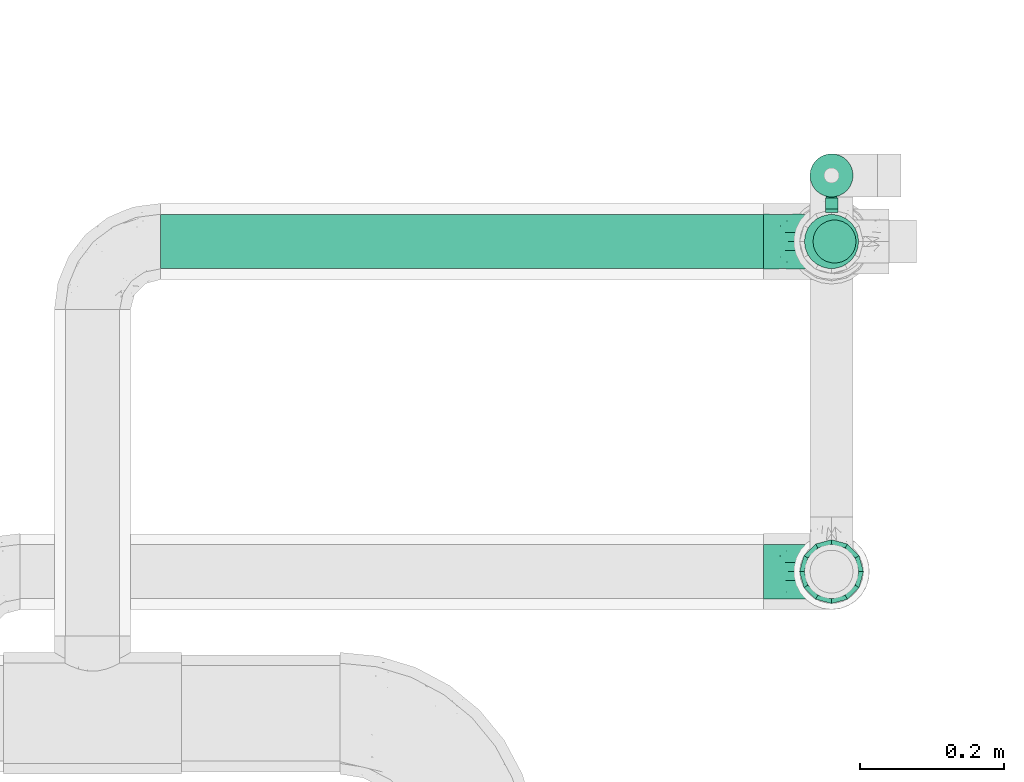
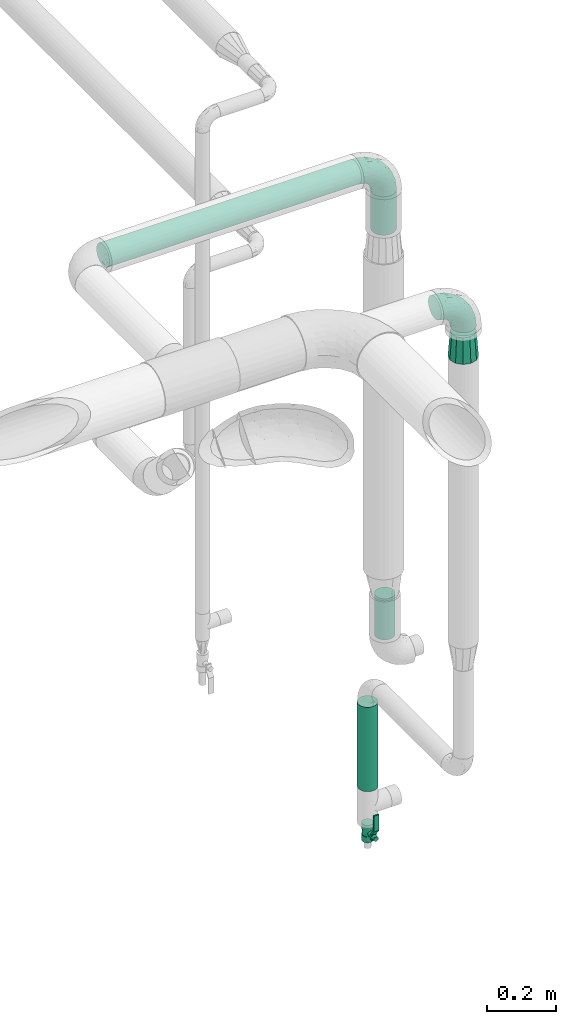
# One storey, part 585 of 827: 4 flow segments, 3 flow fittings, 1 flow controller.
"""IFC2X3 building model written with IfcOpenShell, lengths in millimetres."""

from ifc_helpers import new_model, entity, si_unit, converted_unit, derived_unit, direction, frame, origin, origin_2d_with_axis, place, context, subcontext, project, spatial, polyline, circle, outline, extrude, faceted_brep, source, transform, mapped, material, material_list, type_object, type_shapes, element, save


model = new_model("IFC2X3")

# Units and contexts
model_context = context("Model", 3, precision=0.01, world=origin(), true_north=direction((6.12303176911189e-17, 1.0)))
body_context = subcontext(model_context, "Body", "Model", "MODEL_VIEW")
ifc_project = project(units=[si_unit("LENGTHUNIT", "METRE", prefix="MILLI"), si_unit("AREAUNIT", "SQUARE_METRE"), si_unit("VOLUMEUNIT", "CUBIC_METRE"), converted_unit("PLANEANGLEUNIT", "DEGREE", entity("IfcRatioMeasure", 0.0174532925199433), si_unit("PLANEANGLEUNIT", "RADIAN"), dimensions=[0, 0, 0, 0, 0, 0, 0]), si_unit("MASSUNIT", "GRAM", prefix="KILO"), derived_unit("MASSDENSITYUNIT", [(si_unit("MASSUNIT", "GRAM", prefix="KILO"), 1), (si_unit("LENGTHUNIT", "METRE"), -3)]), derived_unit("MOMENTOFINERTIAUNIT", [(si_unit("LENGTHUNIT", "METRE"), 4)]), si_unit("TIMEUNIT", "SECOND"), si_unit("FREQUENCYUNIT", "HERTZ"), si_unit("THERMODYNAMICTEMPERATUREUNIT", "DEGREE_CELSIUS"), derived_unit("THERMALTRANSMITTANCEUNIT", [(si_unit("MASSUNIT", "GRAM", prefix="KILO"), 1), (si_unit("THERMODYNAMICTEMPERATUREUNIT", "KELVIN"), -1), (si_unit("TIMEUNIT", "SECOND"), -3)]), derived_unit("VOLUMETRICFLOWRATEUNIT", [(si_unit("LENGTHUNIT", "METRE"), 3), (si_unit("TIMEUNIT", "SECOND"), -1)]), derived_unit("MASSFLOWRATEUNIT", [(si_unit("MASSUNIT", "GRAM", prefix="KILO"), 1), (si_unit("TIMEUNIT", "SECOND"), -1)]), derived_unit("ROTATIONALFREQUENCYUNIT", [(si_unit("TIMEUNIT", "SECOND"), -1)]), si_unit("ELECTRICCURRENTUNIT", "AMPERE"), si_unit("ELECTRICVOLTAGEUNIT", "VOLT"), si_unit("POWERUNIT", "WATT"), si_unit("FORCEUNIT", "NEWTON", prefix="KILO"), si_unit("ILLUMINANCEUNIT", "LUX"), si_unit("LUMINOUSFLUXUNIT", "LUMEN"), si_unit("LUMINOUSINTENSITYUNIT", "CANDELA"), derived_unit("USERDEFINED", [(si_unit("MASSUNIT", "GRAM", prefix="KILO"), -1), (si_unit("LENGTHUNIT", "METRE"), -2), (si_unit("TIMEUNIT", "SECOND"), 3), (si_unit("LUMINOUSFLUXUNIT", "LUMEN"), 1)]), derived_unit("LINEARVELOCITYUNIT", [(si_unit("LENGTHUNIT", "METRE"), 1), (si_unit("TIMEUNIT", "SECOND"), -1)]), si_unit("PRESSUREUNIT", "PASCAL"), derived_unit("USERDEFINED", [(si_unit("LENGTHUNIT", "METRE"), -2), (si_unit("MASSUNIT", "GRAM", prefix="KILO"), 1), (si_unit("TIMEUNIT", "SECOND"), -2)]), derived_unit("LINEARFORCEUNIT", [(si_unit("MASSUNIT", "GRAM", prefix="KILO"), 1), (si_unit("LENGTHUNIT", "METRE"), 1), (si_unit("TIMEUNIT", "SECOND"), -2), (si_unit("LENGTHUNIT", "METRE"), -1)]), derived_unit("PLANARFORCEUNIT", [(si_unit("MASSUNIT", "GRAM", prefix="KILO"), 1), (si_unit("LENGTHUNIT", "METRE"), 1), (si_unit("TIMEUNIT", "SECOND"), -2), (si_unit("LENGTHUNIT", "METRE"), -2)])], contexts=[model_context])

# Site, building, storey
site_placement = place(None, origin())
site = spatial("IfcSite", under=ifc_project, at=site_placement, CompositionType="ELEMENT")
building_placement = place(site_placement, origin())
building = spatial("IfcBuilding", under=site, at=building_placement, CompositionType="ELEMENT")
storey_placement = place(building_placement, frame((0.0, 0.0, 28200.0)))
storey = spatial("IfcBuildingStorey", under=building, at=storey_placement, Name="08", CompositionType="ELEMENT", Elevation=28200.0)

# Flow segments
pipe_segment_type = type_object("IfcPipeSegmentType", PredefinedType="NOTDEFINED")
flow_segment_1_placement = place(storey_placement, frame((21734.46, 15367.9, 2760.59)))
element("IfcFlowSegment", 1, at=flow_segment_1_placement, inside=storey, type_object=pipe_segment_type, context=body_context, shape_type="SweptSolid", body=[
    extrude(circle(Radius=37.75, at=origin_2d_with_axis()), frame((0.0, 39.35, 39.35), z_axis=(1.0, 0.0, 0.0), x_axis=(0.0, 1.0, 0.0)), (0.0, 0.0, 1.0), 840.000000000008),
])
flow_segment_2_placement = place(storey_placement, frame((22630.11, 15367.9, 2568.89)))
element("IfcFlowSegment", 2, at=flow_segment_2_placement, inside=storey, type_object=pipe_segment_type, context=body_context, shape_type="SweptSolid", body=[
    extrude(circle(Radius=37.75, at=origin_2d_with_axis()), frame((39.35, 39.35, 0.0)), (0.0, 0.0, 1.0), 136.041437878713),
])
flow_segment_3_placement = place(storey_placement, frame((22637.86, 15467.74, 547.45)))
element("IfcFlowSegment", 3, at=flow_segment_3_placement, inside=storey, type_object=pipe_segment_type, context=body_context, shape_type="SweptSolid", body=[
    extrude(circle(Radius=30.0, at=origin_2d_with_axis()), frame((31.6, 31.6, 0.0)), (0.0, 0.0, 1.0), 297.100324357474),
])
flow_segment_4_placement = place(storey_placement, frame((22642.04, 15375.65, 1136.46)))
element("IfcFlowSegment", 4, at=flow_segment_4_placement, inside=storey, type_object=pipe_segment_type, context=body_context, shape_type="SweptSolid", body=[
    extrude(circle(Radius=30.0, at=origin_2d_with_axis()), frame((31.6, 31.6, 0.0), z_axis=(0.0, 0.0, 1.0), x_axis=(-1.0, 0.0, 0.0)), (0.0, 0.0, 1.0), 144.433983676946),
])

# Flow controller
ifc_material = material()
ifc_material_list = material_list([ifc_material, ifc_material, ifc_material, ifc_material, ifc_material])
valve_type = type_object("IfcValveType", PredefinedType="NOTDEFINED", material=ifc_material_list)
shared_shape_1 = source(origin(), body_context, "Body", "SweptSolid", [
    extrude(circle(Radius=17.5, at=origin_2d_with_axis()), frame((-30.5, 0.0, 0.0), z_axis=(1.0, 0.0, 0.0), x_axis=(0.0, 1.0, 0.0)), (0.0, 0.0, 1.0), 20.3333333333333),
    extrude(circle(Radius=16.0, at=origin_2d_with_axis()), frame((-10.17, 0.0, 0.0), z_axis=(1.0, 0.0, 0.0), x_axis=(0.0, 1.0, 0.0)), (0.0, 0.0, 1.0), 20.3333333333333),
    extrude(circle(Radius=17.5, at=origin_2d_with_axis()), frame((10.17, 0.0, 0.0), z_axis=(1.0, 0.0, 0.0), x_axis=(0.0, 1.0, 0.0)), (0.0, 0.0, 1.0), 20.3333333333333),
    extrude(outline(polyline([(-38.75, -5.0), (-38.75, -10.0), (-17.92, -10.0), (2.08, 5.0), (56.25, 5.0), (56.25, 10.0), (0.42, 10.0), (-19.58, -5.0), (-38.75, -5.0)])), frame((28.75, -8.75, 41.5), z_axis=(0.0, -1.0, 0.0), x_axis=(1.0, 0.0, 0.0)), (0.0, 0.0, -1.0), 17.5),
    extrude(circle(Radius=8.0, at=origin_2d_with_axis()), origin(), (0.0, 0.0, 1.0), 49.0),
])
type_shapes(valve_type, [shared_shape_1])
flow_controller_placement = place(storey_placement, frame((22669.46, 15499.33, 388.95), z_axis=(0.0, -1.0, 0.0), x_axis=(0.0, 0.0, 1.0)))
element("IfcFlowController", 5, at=flow_controller_placement, inside=storey, type_object=valve_type, material=ifc_material, context=body_context, shape_type="MappedRepresentation", body=[
    mapped(shared_shape_1, transform((0.0, 0.0, 0.0), scale=1.0)),
])

# Flow fittings
pipe_fitting_type_1 = type_object("IfcPipeFittingType", Name="ADSK_1", PredefinedType="NOTDEFINED", material=ifc_material)
shared_shape_2 = source(origin(), body_context, "Body", "Brep", [
    faceted_brep([(-95.0, 19.02, -32.95), (-95.0, 9.85, -36.75), (-95.0, 0.0, -38.05), (-95.0, -9.85, -36.75), (-95.0, -19.03, -32.95), (-95.0, -26.91, -26.91), (-95.0, -32.95, -19.03), (-95.0, -36.75, -9.85), (-95.0, -38.05, 0.0), (-95.0, -36.75, 9.85), (-95.0, -32.95, 19.02), (-95.0, -26.91, 26.91), (-95.0, -19.03, 32.95), (-95.0, -9.85, 36.75), (-95.0, 0.0, 38.05), (-95.0, 9.85, 36.75), (-95.0, 19.02, 32.95), (-95.0, 26.91, 26.91), (-95.0, 32.95, 19.02), (-95.0, 36.75, 9.85), (-95.0, 38.05, 0.0), (-95.0, 36.75, -9.85), (-95.0, 32.95, -19.03), (-95.0, 26.91, -26.91), (0.0, 95.0, -38.05), (-9.85, 95.0, -36.75), (-19.02, 95.0, -32.95), (-26.91, 95.0, -26.91), (-32.95, 95.0, -19.03), (-36.75, 95.0, -9.85), (-38.05, 95.0, 0.0), (-36.75, 95.0, 9.85), (-32.95, 95.0, 19.02), (-26.91, 95.0, 26.91), (-19.02, 95.0, 32.95), (-9.85, 95.0, 36.75), (0.0, 95.0, 38.05), (9.85, 95.0, 36.75), (19.03, 95.0, 32.95), (26.91, 95.0, 26.91), (32.95, 95.0, 19.02), (36.75, 95.0, 9.85), (38.05, 95.0, 0.0), (36.75, 95.0, -9.85), (32.95, 95.0, -19.03), (26.91, 95.0, -26.91), (19.03, 95.0, -32.95), (9.85, 95.0, -36.75), (-7.99, -4.96, 6.3), (-0.92, 0.92, 0.0), (4.62, 8.1, 8.01), (-76.19, -35.57, 0.0), (-64.32, -32.32, 12.43), (20.51, 62.45, 28.68), (-60.56, -33.52, 0.0), (-70.4, -13.47, 34.42), (-39.61, -5.88, 32.32), (-49.6, 2.07, 37.1), (-70.34, -28.81, 21.71), (14.64, 40.81, 26.5), (5.88, 39.61, 32.32), (3.59, 20.77, 25.31), (-40.45, 68.06, 16.75), (-62.45, -20.51, 28.68), (-44.52, -26.87, 0.0), (-28.47, -20.22, 0.0), (-26.43, -17.83, 8.75), (-76.1, 39.63, 10.76), (-72.74, 37.58, 18.19), (-60.35, 46.18, 14.61), (-13.4, 13.4, 32.12), (-20.77, -3.59, 25.31), (-14.66, 81.47, 35.56), (-6.22, 71.26, 37.92), (-57.5, 42.48, 22.79), (-15.0, 34.74, 37.7), (-27.1, 12.08, 36.05), (-9.2, 28.81, 35.63), (-79.98, 23.7, 30.95), (-73.68, -4.3, 37.48), (-30.74, 21.67, 37.97), (-62.36, 47.59, 6.79), (-72.71, 32.83, 24.69), (-67.42, 7.02, 37.95), (-32.13, 75.27, 24.51), (-43.46, 51.47, 26.26), (-24.98, 73.15, 31.29), (20.59, 41.28, 19.85), (7.79, 16.09, 15.86), (-73.21, 42.39, 0.0), (-54.73, 54.73, 0.0), (-73.44, 15.79, 35.79), (-5.94, 4.32, 20.43), (28.81, 70.34, 21.71), (32.32, 64.32, 12.43), (-53.59, 26.2, 35.09), (-52.02, 19.31, 37.21), (21.38, 33.53, 10.34), (26.87, 44.52, 0.0), (-48.28, 12.14, 38.05), (4.3, 73.68, 37.48), (-44.08, -25.52, 12.79), (-41.28, -20.59, 19.85), (35.57, 76.19, 0.0), (-47.26, 54.3, 20.18), (-47.4, 61.99, 8.58), (-42.39, 73.21, 0.0), (-39.67, 78.86, 7.21), (-45.69, 36.84, 33.11), (-32.83, 50.13, 33.35), (13.47, 70.4, 34.42), (-18.25, 63.73, 36.07), (-40.63, -13.75, 27.22), (-16.63, 46.37, 37.95), (-53.47, 38.79, 28.59), (-26.07, 48.54, 36.15), (-34.51, 34.51, 36.86), (-2.07, 49.6, 37.1), (-22.79, -10.49, 19.23), (-61.73, 28.67, 31.87), (9.65, 14.7, 0.0), (20.22, 28.47, 0.0), (33.52, 60.56, 0.0), (-11.42, -5.44, 13.25), (-14.7, -9.65, 0.0), (-81.47, 14.66, -35.56), (-62.45, -20.51, -28.68), (-71.26, 6.22, -37.92), (-75.27, 32.13, -24.51), (-73.15, 24.98, -31.29), (13.47, 70.4, -34.42), (5.88, 39.61, -32.32), (-2.07, 49.6, -37.1), (-78.86, 39.67, -7.21), (-70.4, -13.47, -34.42), (-39.61, -5.88, -32.32), (-61.99, 47.4, -8.58), (32.32, 64.32, -12.43), (28.81, 70.34, -21.71), (-63.73, 18.25, -36.07), (-50.13, 32.83, -33.35), (4.3, 73.68, -37.48), (-7.02, 67.42, -37.95), (-39.63, 76.1, -10.76), (-46.18, 60.35, -14.61), (-47.59, 62.36, -6.79), (-64.32, -32.32, -12.43), (-26.2, 53.59, -35.09), (-15.79, 73.44, -35.79), (-19.31, 52.02, -37.21), (-37.58, 72.74, -18.19), (-70.34, -28.81, -21.71), (-42.48, 57.5, -22.79), (-38.79, 53.47, -28.59), (-51.47, 43.46, -26.26), (-32.83, 72.71, -24.69), (-46.37, 16.63, -37.95), (-73.68, -4.3, -37.48), (-41.28, -20.59, -19.85), (-44.08, -25.52, -12.79), (13.75, 40.63, -27.22), (20.51, 62.45, -28.68), (-68.06, 40.45, -16.75), (-54.3, 47.26, -20.18), (-12.14, 48.28, -38.05), (-21.67, 30.74, -37.97), (-36.84, 45.69, -33.11), (-11.42, -5.44, -13.25), (7.79, 16.09, -15.86), (4.62, 8.1, -8.01), (-23.7, 79.98, -30.95), (-26.43, -17.83, -8.75), (-7.99, -4.96, -6.3), (-40.81, -14.64, -26.5), (-20.77, -3.59, -25.31), (-34.74, 15.0, -37.7), (-12.08, 27.1, -36.05), (-28.81, 9.2, -35.63), (-22.79, -10.49, -19.23), (21.38, 33.53, -10.34), (20.59, 41.28, -19.85), (-48.54, 26.07, -36.15), (-49.6, 2.07, -37.1), (-13.4, 13.4, -32.12), (3.59, 20.77, -25.31), (-28.67, 61.73, -31.87), (-34.51, 34.51, -36.86), (-5.94, 4.32, -20.43)], [[[0, 1, 2, 3, 4, 5, 6, 7, 8, 9, 10, 11, 12, 13, 14, 15, 16, 17, 18, 19, 20, 21, 22, 23]], [[24, 25, 26, 27, 28, 29, 30, 31, 32, 33, 34, 35, 36, 37, 38, 39, 40, 41, 42, 43, 44, 45, 46, 47]], [[48, 49, 50]], [[51, 52, 9]], [[53, 39, 38]], [[9, 52, 10]], [[54, 52, 51]], [[55, 56, 57]], [[11, 10, 58]], [[59, 60, 61]], [[32, 31, 62]], [[63, 12, 11]], [[63, 55, 12]], [[64, 65, 66]], [[67, 68, 69]], [[70, 56, 71]], [[35, 72, 73]], [[69, 68, 74]], [[75, 76, 77]], [[16, 78, 17]], [[13, 79, 14]], [[76, 75, 80]], [[67, 69, 81]], [[18, 17, 82]], [[14, 79, 83]], [[20, 19, 67]], [[84, 85, 86]], [[87, 61, 88]], [[89, 81, 90]], [[18, 82, 68]], [[15, 91, 16]], [[14, 83, 15]], [[71, 92, 61]], [[17, 78, 82]], [[93, 87, 94]], [[95, 91, 96]], [[97, 98, 94]], [[86, 72, 34]], [[96, 99, 80]], [[37, 36, 100]], [[40, 39, 93]], [[40, 94, 41]], [[64, 66, 101]], [[93, 94, 40]], [[58, 102, 63]], [[94, 103, 41]], [[94, 87, 97]], [[104, 69, 74]], [[34, 33, 86]], [[105, 69, 104]], [[52, 58, 10]], [[106, 107, 30]], [[108, 109, 85]], [[105, 106, 90]], [[53, 110, 60]], [[86, 111, 72]], [[86, 109, 111]], [[33, 84, 86]], [[12, 55, 13]], [[112, 56, 63]], [[110, 38, 37]], [[34, 72, 35]], [[36, 35, 73]], [[111, 113, 73]], [[105, 107, 106]], [[110, 53, 38]], [[74, 114, 85]], [[91, 15, 83]], [[105, 90, 81]], [[107, 62, 31]], [[33, 32, 84]], [[115, 109, 116]], [[111, 115, 113]], [[100, 73, 117]], [[56, 55, 63]], [[79, 55, 57]], [[102, 118, 112]], [[56, 70, 76]], [[100, 110, 37]], [[117, 77, 60]], [[117, 60, 110]], [[60, 70, 61]], [[58, 52, 101]], [[63, 11, 58]], [[39, 53, 93]], [[87, 93, 53]], [[96, 91, 83]], [[78, 91, 119]], [[32, 62, 84]], [[84, 62, 104]], [[86, 85, 109]], [[85, 114, 108]], [[80, 113, 116]], [[117, 73, 113]], [[80, 116, 96]], [[80, 57, 76]], [[71, 112, 118]], [[61, 87, 59]], [[62, 107, 105]], [[97, 120, 121]], [[70, 71, 61]], [[71, 118, 92]], [[73, 100, 36]], [[110, 100, 117]], [[55, 79, 13]], [[83, 79, 57]], [[96, 83, 99]], [[116, 108, 95]], [[50, 97, 88]], [[97, 87, 88]], [[50, 49, 120]], [[122, 94, 98]], [[89, 20, 67]], [[105, 81, 69]], [[89, 67, 81]], [[68, 19, 18]], [[68, 67, 19]], [[74, 68, 82]], [[114, 82, 119]], [[74, 85, 104]], [[82, 114, 74]], [[114, 119, 108]], [[95, 108, 119]], [[116, 109, 108]], [[123, 48, 50]], [[97, 50, 120]], [[123, 50, 88]], [[91, 95, 119]], [[116, 95, 96]], [[84, 104, 85]], [[104, 62, 105]], [[83, 57, 99]], [[57, 80, 99]], [[66, 48, 123]], [[66, 124, 48]], [[118, 66, 123]], [[124, 66, 65]], [[66, 118, 101]], [[54, 64, 52]], [[124, 49, 48]], [[30, 107, 31]], [[91, 78, 16]], [[82, 78, 119]], [[56, 76, 57]], [[77, 76, 70]], [[60, 77, 70]], [[77, 117, 75]], [[117, 113, 75]], [[113, 80, 75]], [[9, 8, 51]], [[103, 94, 122]], [[103, 42, 41]], [[73, 72, 111]], [[113, 115, 116]], [[111, 109, 115]], [[102, 112, 63]], [[71, 56, 112]], [[118, 102, 101]], [[92, 123, 88]], [[123, 92, 118]], [[61, 92, 88]], [[87, 53, 59]], [[60, 59, 53]], [[97, 121, 98]], [[58, 101, 102]], [[64, 101, 52]], [[125, 1, 0]], [[126, 5, 4]], [[2, 1, 127]], [[1, 125, 127]], [[128, 129, 23]], [[130, 131, 132]], [[89, 133, 20]], [[126, 134, 135]], [[136, 89, 90]], [[137, 138, 44]], [[139, 129, 140]], [[24, 141, 142]], [[143, 144, 145]], [[125, 129, 139]], [[6, 146, 7]], [[147, 148, 149]], [[146, 51, 7]], [[143, 150, 144]], [[146, 6, 151]], [[152, 153, 154]], [[126, 4, 134]], [[0, 23, 129]], [[28, 155, 150]], [[43, 42, 103]], [[54, 146, 64]], [[139, 156, 127]], [[157, 3, 2]], [[151, 158, 159]], [[160, 131, 161]], [[22, 21, 162]], [[136, 144, 163]], [[149, 164, 165]], [[24, 142, 25]], [[166, 140, 154]], [[154, 129, 128]], [[143, 30, 29]], [[167, 168, 169]], [[155, 28, 27]], [[26, 170, 27]], [[171, 167, 172]], [[26, 25, 148]], [[27, 170, 155]], [[173, 135, 174]], [[144, 150, 152]], [[175, 176, 177]], [[24, 47, 141]], [[45, 161, 46]], [[148, 25, 142]], [[176, 175, 165]], [[64, 159, 171]], [[138, 45, 44]], [[130, 46, 161]], [[137, 44, 43]], [[178, 159, 158]], [[137, 103, 122]], [[163, 144, 152]], [[136, 133, 89]], [[103, 137, 43]], [[6, 5, 151]], [[178, 158, 173]], [[134, 4, 3]], [[178, 173, 174]], [[137, 98, 179]], [[145, 90, 106]], [[138, 180, 161]], [[46, 130, 47]], [[136, 90, 145]], [[133, 162, 21]], [[23, 22, 128]], [[139, 140, 181]], [[139, 181, 156]], [[157, 127, 182]], [[157, 134, 3]], [[182, 177, 135]], [[182, 135, 134]], [[135, 183, 174]], [[131, 130, 161]], [[141, 130, 132]], [[160, 180, 184]], [[131, 183, 176]], [[5, 126, 151]], [[158, 151, 126]], [[180, 138, 137]], [[161, 45, 138]], [[149, 148, 142]], [[170, 148, 185]], [[22, 162, 128]], [[128, 162, 163]], [[129, 154, 140]], [[154, 153, 166]], [[165, 156, 186]], [[182, 127, 156]], [[165, 186, 149]], [[165, 132, 176]], [[131, 184, 183]], [[187, 167, 178]], [[184, 168, 187]], [[167, 169, 172]], [[184, 180, 168]], [[174, 183, 184]], [[127, 157, 2]], [[134, 157, 182]], [[130, 141, 47]], [[142, 141, 132]], [[149, 142, 164]], [[186, 166, 147]], [[180, 179, 168]], [[169, 179, 120]], [[137, 179, 180]], [[179, 121, 120]], [[106, 30, 143]], [[136, 145, 144]], [[106, 143, 145]], [[150, 29, 28]], [[150, 143, 29]], [[152, 150, 155]], [[153, 155, 185]], [[152, 154, 163]], [[155, 153, 152]], [[153, 185, 166]], [[147, 166, 185]], [[186, 140, 166]], [[169, 120, 49]], [[169, 49, 172]], [[179, 169, 168]], [[148, 147, 185]], [[186, 147, 149]], [[128, 163, 154]], [[163, 162, 136]], [[142, 132, 164]], [[132, 165, 164]], [[171, 124, 65]], [[124, 171, 172]], [[64, 146, 159]], [[171, 159, 178]], [[171, 65, 64]], [[172, 49, 124]], [[162, 133, 136]], [[20, 133, 21]], [[148, 170, 26]], [[155, 170, 185]], [[131, 176, 132]], [[177, 176, 183]], [[135, 177, 183]], [[177, 182, 175]], [[182, 156, 175]], [[156, 165, 175]], [[51, 146, 54]], [[51, 8, 7]], [[129, 125, 0]], [[127, 125, 139]], [[140, 186, 181]], [[156, 181, 186]], [[158, 126, 173]], [[135, 173, 126]], [[187, 178, 174]], [[171, 178, 167]], [[184, 187, 174]], [[167, 187, 168]], [[180, 160, 161]], [[184, 131, 160]], [[98, 137, 122]], [[98, 121, 179]], [[151, 159, 146]]]),
])
type_shapes(pipe_fitting_type_1, [shared_shape_2])
for number, where, z_axis, x_axis, name in (
    (6, (22669.46, 15407.25, 2799.93), (0.0, 1.0, 0.0), (1.0, 0.0, 0.0), "ADSK_1"),
    (7, (22669.46, 14947.25, 2600.0), (0.0, 1.0, 0.0), (1.0, 0.0, 0.0), "ADSK_1"),
):
    element("IfcFlowFitting", number, at=place(storey_placement, frame(where, z_axis=z_axis, x_axis=x_axis)), inside=storey, type_object=pipe_fitting_type_1, material=ifc_material, Name=name, ObjectType="ADSK_1", context=body_context, shape_type="MappedRepresentation", body=[
        mapped(shared_shape_2, transform((0.0, 0.0, 0.0), scale=1.0)),
    ])
pipe_fitting_type_2 = type_object("IfcPipeFittingType", Name="ADSK_1", PredefinedType="NOTDEFINED", material=ifc_material)
shared_shape_3 = source(origin(), body_context, "Body", "Brep", [
    faceted_brep([(89.0, -44.45, 0.0), (89.0, -41.96, -9.31), (89.0, -38.49, -22.22), (89.0, -30.36, -30.36), (89.0, -22.23, -38.49), (89.0, -11.11, -41.47), (89.0, 0.0, -44.45), (89.0, 11.11, -41.47), (89.0, 22.22, -38.49), (89.0, 30.36, -30.36), (89.0, 38.49, -22.22), (89.0, 41.96, -9.31), (89.0, 44.45, 0.0), (89.0, 41.96, 9.31), (89.0, 38.49, 22.23), (89.0, 30.36, 30.36), (89.0, 22.22, 38.49), (89.0, 11.11, 41.47), (89.0, 0.0, 44.45), (89.0, -11.11, 41.47), (89.0, -22.23, 38.49), (89.0, -30.36, 30.36), (89.0, -38.49, 22.23), (89.0, -41.96, 9.31), (0.0, 38.05, 0.0), (0.0, 35.5, -9.51), (0.0, 32.95, -19.02), (0.0, 25.99, -25.99), (0.0, 19.02, -32.95), (0.0, 9.51, -35.5), (0.0, 0.0, -38.05), (0.0, -9.51, -35.5), (0.0, -19.03, -32.95), (0.0, -25.99, -25.99), (0.0, -32.95, -19.02), (0.0, -35.5, -9.51), (0.0, -38.05, 0.0), (0.0, -35.5, 9.51), (0.0, -32.95, 19.03), (0.0, -25.99, 25.99), (0.0, -19.03, 32.95), (0.0, -9.51, 35.5), (0.0, 0.0, 38.05), (0.0, 9.51, 35.5), (0.0, 19.03, 32.95), (0.0, 25.99, 25.99), (0.0, 32.95, 19.03), (0.0, 35.5, 9.51)], [[[0, 1, 2, 3, 4, 5, 6, 7, 8, 9, 10, 11, 12, 13, 14, 15, 16, 17, 18, 19, 20, 21, 22, 23]], [[24, 25, 26, 27, 28, 29, 30, 31, 32, 33, 34, 35, 36, 37, 38, 39, 40, 41, 42, 43, 44, 45, 46, 47]], [[2, 1, 0, 36, 35, 34]], [[28, 8, 7, 6, 30, 29]], [[32, 4, 3, 2, 34, 33]], [[5, 4, 32, 31, 30, 6]], [[10, 26, 25, 24, 12, 11]], [[9, 8, 28, 27, 26, 10]], [[14, 13, 12, 24, 47, 46]], [[40, 20, 19, 18, 42, 41]], [[44, 16, 15, 14, 46, 45]], [[17, 16, 44, 43, 42, 18]], [[22, 38, 37, 36, 0, 23]], [[21, 20, 40, 39, 38, 22]]]),
])
type_shapes(pipe_fitting_type_2, [shared_shape_3])
flow_fitting_placement = place(storey_placement, frame((22669.46, 14947.25, 2486.5), z_axis=(-1.0, 0.0, 0.0), x_axis=(0.0, 0.0, -1.0)))
element("IfcFlowFitting", 8, at=flow_fitting_placement, inside=storey, type_object=pipe_fitting_type_2, material=ifc_material, Name="ADSK_1", ObjectType="ADSK_1", context=body_context, shape_type="MappedRepresentation", body=[
    mapped(shared_shape_3, transform((0.0, 0.0, 0.0), scale=1.0)),
])

save(model, "model.ifc")
